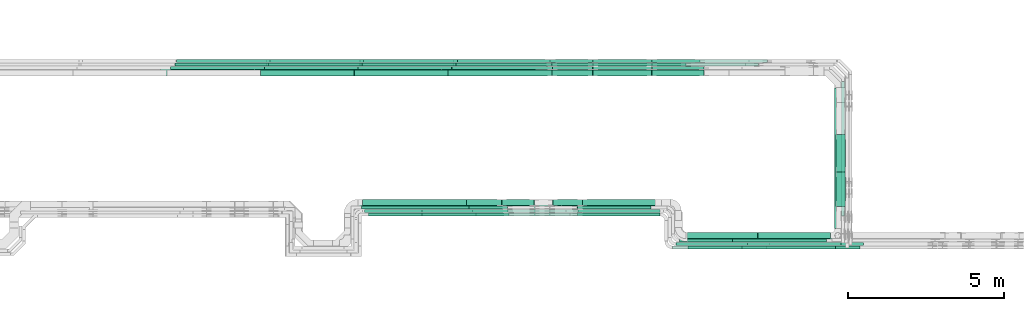
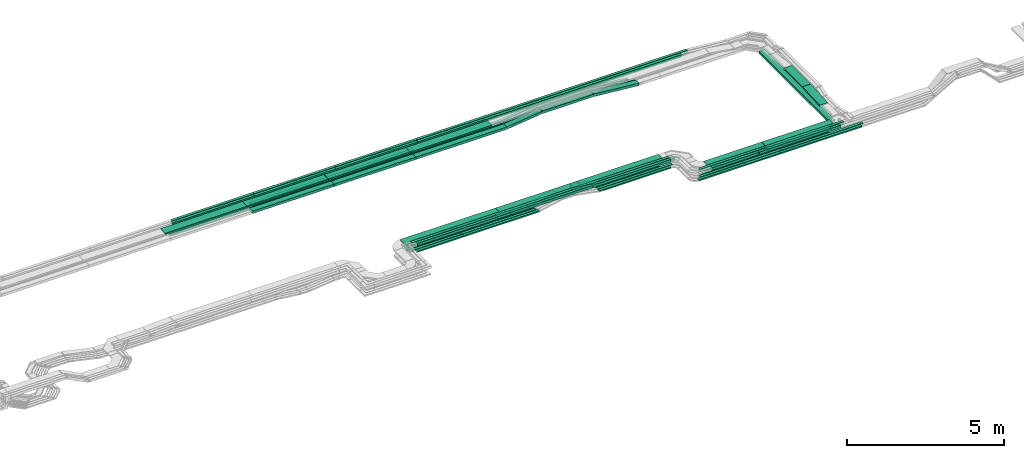
# One storey, part 3 of 32: 78 flow segments.
"""IFC2X3 building model written with IfcOpenShell, lengths in millimetres."""

from ifc_helpers import new_model, entity, si_unit, converted_unit, derived_unit, direction, frame, frame_2d, origin, origin_2d_with_axis, place, context, subcontext, project, spatial, rectangle, extrude, type_object, element, save


model = new_model("IFC2X3")

# Units and contexts
model_context = context("Model", 3, precision=0.01, world=origin(), true_north=direction((6.12303176911189e-17, 1.0)))
body_context = subcontext(model_context, "Body", "Model", "MODEL_VIEW")
ifc_project = project(units=[si_unit("LENGTHUNIT", "METRE", prefix="MILLI"), si_unit("AREAUNIT", "SQUARE_METRE"), si_unit("VOLUMEUNIT", "CUBIC_METRE"), converted_unit("PLANEANGLEUNIT", "DEGREE", entity("IfcRatioMeasure", 0.0174532925199433), si_unit("PLANEANGLEUNIT", "RADIAN"), dimensions=[0, 0, 0, 0, 0, 0, 0]), si_unit("MASSUNIT", "GRAM", prefix="KILO"), derived_unit("MASSDENSITYUNIT", [(si_unit("MASSUNIT", "GRAM", prefix="KILO"), 1), (si_unit("LENGTHUNIT", "METRE"), -3)]), derived_unit("MOMENTOFINERTIAUNIT", [(si_unit("LENGTHUNIT", "METRE"), 4)]), si_unit("TIMEUNIT", "SECOND"), si_unit("FREQUENCYUNIT", "HERTZ"), si_unit("THERMODYNAMICTEMPERATUREUNIT", "DEGREE_CELSIUS"), derived_unit("THERMALTRANSMITTANCEUNIT", [(si_unit("MASSUNIT", "GRAM", prefix="KILO"), 1), (si_unit("THERMODYNAMICTEMPERATUREUNIT", "KELVIN"), -1), (si_unit("TIMEUNIT", "SECOND"), -3)]), derived_unit("VOLUMETRICFLOWRATEUNIT", [(si_unit("LENGTHUNIT", "METRE"), 3), (si_unit("TIMEUNIT", "SECOND"), -1)]), derived_unit("MASSFLOWRATEUNIT", [(si_unit("MASSUNIT", "GRAM", prefix="KILO"), 1), (si_unit("TIMEUNIT", "SECOND"), -1)]), derived_unit("ROTATIONALFREQUENCYUNIT", [(si_unit("TIMEUNIT", "SECOND"), -1)]), si_unit("ELECTRICCURRENTUNIT", "AMPERE"), si_unit("ELECTRICVOLTAGEUNIT", "VOLT"), si_unit("POWERUNIT", "WATT"), si_unit("FORCEUNIT", "NEWTON", prefix="KILO"), si_unit("ILLUMINANCEUNIT", "LUX"), si_unit("LUMINOUSFLUXUNIT", "LUMEN"), si_unit("LUMINOUSINTENSITYUNIT", "CANDELA"), derived_unit("USERDEFINED", [(si_unit("MASSUNIT", "GRAM", prefix="KILO"), -1), (si_unit("LENGTHUNIT", "METRE"), -2), (si_unit("TIMEUNIT", "SECOND"), 3), (si_unit("LUMINOUSFLUXUNIT", "LUMEN"), 1)]), derived_unit("LINEARVELOCITYUNIT", [(si_unit("LENGTHUNIT", "METRE"), 1), (si_unit("TIMEUNIT", "SECOND"), -1)]), si_unit("PRESSUREUNIT", "PASCAL"), derived_unit("USERDEFINED", [(si_unit("LENGTHUNIT", "METRE"), -2), (si_unit("MASSUNIT", "GRAM", prefix="KILO"), 1), (si_unit("TIMEUNIT", "SECOND"), -2)]), derived_unit("LINEARFORCEUNIT", [(si_unit("MASSUNIT", "GRAM", prefix="KILO"), 1), (si_unit("LENGTHUNIT", "METRE"), 1), (si_unit("TIMEUNIT", "SECOND"), -2), (si_unit("LENGTHUNIT", "METRE"), -1)]), derived_unit("PLANARFORCEUNIT", [(si_unit("MASSUNIT", "GRAM", prefix="KILO"), 1), (si_unit("LENGTHUNIT", "METRE"), 1), (si_unit("TIMEUNIT", "SECOND"), -2), (si_unit("LENGTHUNIT", "METRE"), -2)])], contexts=[model_context])

# Site, building, storey
site_placement = place(None, origin())
site = spatial("IfcSite", under=ifc_project, at=site_placement, CompositionType="ELEMENT")
building_placement = place(site_placement, origin())
building = spatial("IfcBuilding", under=site, at=building_placement, CompositionType="ELEMENT")
storey_placement = place(building_placement, frame((0.0, 0.0, 8100.0)))
storey = spatial("IfcBuildingStorey", under=building, at=storey_placement, CompositionType="ELEMENT", Elevation=8100.0)

# Flow segments
cable_carrier_segment_type = type_object("IfcCableCarrierSegmentType", PredefinedType="CABLETRAYSEGMENT")
flow_segment_1_placement = place(storey_placement, frame((45344.9, 9694.99, 2799.27)))
element("IfcFlowSegment", 1, at=flow_segment_1_placement, inside=storey, type_object=cable_carrier_segment_type, context=body_context, shape_type="SweptSolid", body=[
    extrude(rectangle(XDim=99.9999999999999, YDim=3442.93310217287, at=frame_2d((0.0, 0.0), x_axis=(0.0, 1.0))), frame((1721.47, 50.0, 0.01), z_axis=(4.01733183785302e-07, 0.000204778842241825, 0.999999979032732), x_axis=(1.0, 0.0, -4.01733192208904e-07)), (0.0, 0.0, 1.0), 100.0),
])
flow_segment_2_placement = place(storey_placement, frame((60470.11, 9693.6, 2550.0)))
element("IfcFlowSegment", 2, at=flow_segment_2_placement, inside=storey, type_object=cable_carrier_segment_type, context=body_context, shape_type="SweptSolid", body=[
    extrude(rectangle(XDim=4312.67919252471, YDim=99.9999999999946, at=origin_2d_with_axis()), frame((50.0, 2156.34, 0.0), z_axis=(0.0, 0.0, 1.0), x_axis=(0.0, -1.0, 0.0)), (0.0, 0.0, 1.0), 50.0000000000038),
])
flow_segment_3_placement = place(storey_placement, frame((55181.11, 8749.98, 2549.87)))
element("IfcFlowSegment", 3, at=flow_segment_3_placement, inside=storey, type_object=cable_carrier_segment_type, context=body_context, shape_type="SweptSolid", body=[
    extrude(rectangle(XDim=2998.73000000509, YDim=99.9999999999989, at=origin_2d_with_axis()), frame((1499.37, 50.0, 0.0)), (0.0, 0.0, 1.0), 49.9999999999995),
])
flow_segment_4_placement = place(storey_placement, frame((55071.11, 8639.98, 2548.16)))
element("IfcFlowSegment", 4, at=flow_segment_4_placement, inside=storey, type_object=cable_carrier_segment_type, context=body_context, shape_type="SweptSolid", body=[
    extrude(rectangle(XDim=2998.73000000509, YDim=100.000000000001, at=origin_2d_with_axis()), frame((1499.37, 50.0, 0.0)), (0.0, 0.0, 1.0), 49.9999999999995),
])
flow_segment_5_placement = place(storey_placement, frame((47050.03, 9805.0, 2546.32)))
element("IfcFlowSegment", 5, at=flow_segment_5_placement, inside=storey, type_object=cable_carrier_segment_type, context=body_context, shape_type="SweptSolid", body=[
    extrude(rectangle(XDim=2747.08735792927, YDim=99.9999999999989, at=origin_2d_with_axis()), frame((1373.54, 50.0, 0.0)), (0.0, 0.0, 1.0), 50.0000000000016),
])
flow_segment_6_placement = place(storey_placement, frame((45109.39, 9915.0, 2544.93)))
element("IfcFlowSegment", 6, at=flow_segment_6_placement, inside=storey, type_object=cable_carrier_segment_type, context=body_context, shape_type="SweptSolid", body=[
    extrude(rectangle(XDim=3442.93310217291, YDim=99.9999999999989, at=origin_2d_with_axis()), frame((1721.47, 50.0, 0.0)), (0.0, 0.0, 1.0), 50.0000000000016),
])
flow_segment_7_placement = place(storey_placement, frame((45145.39, 10025.0, 2547.39)))
element("IfcFlowSegment", 7, at=flow_segment_7_placement, inside=storey, type_object=cable_carrier_segment_type, context=body_context, shape_type="SweptSolid", body=[
    extrude(rectangle(XDim=3327.94024484785, YDim=200.000000000002, at=origin_2d_with_axis()), frame((1663.97, 100.0, 0.0)), (0.0, 0.0, 1.0), 99.9999999999989),
])
flow_segment_8_placement = place(storey_placement, frame((47050.03, 9695.0, 2546.67)))
element("IfcFlowSegment", 8, at=flow_segment_8_placement, inside=storey, type_object=cable_carrier_segment_type, context=body_context, shape_type="SweptSolid", body=[
    extrude(rectangle(XDim=2786.58976200292, YDim=99.9999999999989, at=origin_2d_with_axis()), frame((1393.29, 50.0, 0.0)), (0.0, 0.0, 1.0), 50.0000000000016),
])
flow_segment_9_placement = place(storey_placement, frame((52023.2, 9915.0, 2549.87)))
element("IfcFlowSegment", 9, at=flow_segment_9_placement, inside=storey, type_object=cable_carrier_segment_type, context=body_context, shape_type="SweptSolid", body=[
    extrude(rectangle(XDim=2356.3241779721, YDim=99.9999999999989, at=origin_2d_with_axis()), frame((1178.16, 50.0, 0.0), z_axis=(0.0, 0.0, 1.0), x_axis=(-1.0, 0.0, 0.0)), (0.0, 0.0, 1.0), 50.0000000000016),
])
flow_segment_10_placement = place(storey_placement, frame((52525.14, 14174.5, 2704.58)))
element("IfcFlowSegment", 10, at=flow_segment_10_placement, inside=storey, type_object=cable_carrier_segment_type, context=body_context, shape_type="SweptSolid", body=[
    extrude(rectangle(XDim=1876.86289906557, YDim=200.000000000002, at=origin_2d_with_axis()), frame((938.43, 100.0, 0.0)), (0.0, 0.0, 1.0), 99.9999999999989),
])
flow_segment_11_placement = place(storey_placement, frame((52523.64, 14382.28, 2704.03)))
element("IfcFlowSegment", 11, at=flow_segment_11_placement, inside=storey, type_object=cable_carrier_segment_type, context=body_context, shape_type="SweptSolid", body=[
    extrude(rectangle(XDim=1879.49381672388, YDim=99.9999999999989, at=origin_2d_with_axis()), frame((939.75, 50.0, 0.0), z_axis=(0.0, 0.0, 1.0), x_axis=(-1.0, 0.0, 0.0)), (0.0, 0.0, 1.0), 50.0000000000016),
])
flow_segment_12_placement = place(storey_placement, frame((52525.62, 14492.28, 2704.02)))
element("IfcFlowSegment", 12, at=flow_segment_12_placement, inside=storey, type_object=cable_carrier_segment_type, context=body_context, shape_type="SweptSolid", body=[
    extrude(rectangle(XDim=1881.17742834909, YDim=99.9999999999989, at=origin_2d_with_axis()), frame((940.59, 50.0, 0.0), z_axis=(0.0, 0.0, 1.0), x_axis=(-1.0, 0.0, 0.0)), (0.0, 0.0, 1.0), 50.0000000000016),
])
flow_segment_13_placement = place(storey_placement, frame((52523.56, 14602.28, 2704.5)))
element("IfcFlowSegment", 13, at=flow_segment_13_placement, inside=storey, type_object=cable_carrier_segment_type, context=body_context, shape_type="SweptSolid", body=[
    extrude(rectangle(XDim=1879.86643624629, YDim=99.9999999999989, at=origin_2d_with_axis()), frame((939.93, 50.0, 0.0), z_axis=(0.0, 0.0, 1.0), x_axis=(-1.0, 0.0, 0.0)), (0.0, 0.0, 1.0), 50.0000000000016),
])
flow_segment_14_placement = place(storey_placement, frame((48186.7, 14602.28, 2855.0)))
element("IfcFlowSegment", 14, at=flow_segment_14_placement, inside=storey, type_object=cable_carrier_segment_type, context=body_context, shape_type="SweptSolid", body=[
    extrude(rectangle(XDim=9916.000468824, YDim=99.9999999999989, at=origin_2d_with_axis()), frame((4958.0, 50.0, 0.0), z_axis=(0.0, 0.0, 1.0), x_axis=(-1.0, 0.0, 0.0)), (0.0, 0.0, 1.0), 99.9999999999989),
])
flow_segment_15_placement = place(storey_placement, frame((48139.57, 14492.28, 2855.0)))
element("IfcFlowSegment", 15, at=flow_segment_15_placement, inside=storey, type_object=cable_carrier_segment_type, context=body_context, shape_type="SweptSolid", body=[
    extrude(rectangle(XDim=9680.19408379606, YDim=99.9999999999989, at=origin_2d_with_axis()), frame((4840.1, 50.0, 0.0), z_axis=(0.0, 0.0, 1.0), x_axis=(-1.0, 0.0, 0.0)), (0.0, 0.0, 1.0), 100.000000000001),
])
flow_segment_16_placement = place(storey_placement, frame((54405.82, 14602.28, 2550.37)))
element("IfcFlowSegment", 16, at=flow_segment_16_placement, inside=storey, type_object=cable_carrier_segment_type, context=body_context, shape_type="SweptSolid", body=[
    extrude(rectangle(XDim=50.0000000000019, YDim=99.9999999999989, at=frame_2d((0.0, 0.0), x_axis=(0.0, 1.0))), frame((2.49, 50.0, 178.89), z_axis=(0.995008976454959, 0.0, -0.0997854537197453), x_axis=(0.0, 1.0, 0.0)), (0.0, 0.0, 1.0), 1543.44232698593),
])
flow_segment_17_placement = place(storey_placement, frame((51155.3, 14602.28, 2549.33)))
element("IfcFlowSegment", 17, at=flow_segment_17_placement, inside=storey, type_object=cable_carrier_segment_type, context=body_context, shape_type="SweptSolid", body=[
    extrude(rectangle(XDim=49.9999999999997, YDim=99.9999999999989, at=frame_2d((0.0, 0.0), x_axis=(0.0, 1.0))), frame((2.83, 50.0, 24.84), z_axis=(0.993566510793554, 0.0, 0.113250115362077), x_axis=(0.0, 1.0, 0.0)), (0.0, 0.0, 1.0), 1368.9632988374),
])
flow_segment_18_placement = place(storey_placement, frame((51204.64, 14492.28, 2548.84)))
element("IfcFlowSegment", 18, at=flow_segment_18_placement, inside=storey, type_object=cable_carrier_segment_type, context=body_context, shape_type="SweptSolid", body=[
    extrude(rectangle(XDim=50.0000000000001, YDim=99.9999999999989, at=origin_2d_with_axis()), frame((2.93, 50.0, 24.83), z_axis=(0.993097003616306, 0.0, 0.117295956487492), x_axis=(-0.117295956487492, 0.0, 0.993097003616306)), (0.0, 0.0, 1.0), 1321.78049567335),
])
flow_segment_19_placement = place(storey_placement, frame((54409.35, 14492.28, 2550.67)))
element("IfcFlowSegment", 19, at=flow_segment_19_placement, inside=storey, type_object=cable_carrier_segment_type, context=body_context, shape_type="SweptSolid", body=[
    extrude(rectangle(XDim=50.0000000000019, YDim=99.9999999999989, at=frame_2d((0.0, 0.0), x_axis=(0.0, 1.0))), frame((3.49, 50.0, 177.93), z_axis=(0.990180361963206, 0.0, -0.139795746653517), x_axis=(0.0, 1.0, 0.0)), (0.0, 0.0, 1.0), 1095.69661901961),
])
flow_segment_20_placement = place(storey_placement, frame((54405.5, 14382.28, 2550.32)))
element("IfcFlowSegment", 20, at=flow_segment_20_placement, inside=storey, type_object=cable_carrier_segment_type, context=body_context, shape_type="SweptSolid", body=[
    extrude(rectangle(XDim=49.9999999999988, YDim=99.9999999999989, at=origin_2d_with_axis()), frame((2.29, 50.0, 178.5), z_axis=(0.995808315172805, 0.0, -0.0914647442061654), x_axis=(0.0914647442061654, 0.0, 0.995808315172805)), (0.0, 0.0, 1.0), 1679.34670108359),
])
flow_segment_21_placement = place(storey_placement, frame((51225.84, 14382.28, 2549.38)))
element("IfcFlowSegment", 21, at=flow_segment_21_placement, inside=storey, type_object=cable_carrier_segment_type, context=body_context, shape_type="SweptSolid", body=[
    extrude(rectangle(XDim=50.0000000000011, YDim=99.9999999999989, at=frame_2d((0.0, 0.0), x_axis=(0.0, 1.0))), frame((2.97, 50.0, 24.82), z_axis=(0.992897734535622, 0.0, 0.118970957607431), x_axis=(0.0, 1.0, 0.0)), (0.0, 0.0, 1.0), 1298.61326955361),
])
flow_segment_22_placement = place(storey_placement, frame((54404.36, 14174.5, 2550.53)))
element("IfcFlowSegment", 22, at=flow_segment_22_placement, inside=storey, type_object=cable_carrier_segment_type, context=body_context, shape_type="SweptSolid", body=[
    extrude(rectangle(XDim=99.999999999999, YDim=200.000000000002, at=origin_2d_with_axis()), frame((4.59, 100.0, 203.73), z_axis=(0.995778345359133, 0.0, -0.0917904511037341), x_axis=(0.0917904511037341, 0.0, 0.995778345359133)), (0.0, 0.0, 1.0), 1677.07211589127),
])
flow_segment_23_placement = place(storey_placement, frame((51219.72, 14174.5, 2549.73)))
element("IfcFlowSegment", 23, at=flow_segment_23_placement, inside=storey, type_object=cable_carrier_segment_type, context=body_context, shape_type="SweptSolid", body=[
    extrude(rectangle(XDim=100.0, YDim=200.000000000002, at=frame_2d((0.0, 0.0), x_axis=(0.0, 1.0))), frame((5.95, 100.0, 49.64), z_axis=(0.992897734535643, 0.0, 0.11897095760726), x_axis=(0.0, 1.0, 0.0)), (0.0, 0.0, 1.0), 1300.29007254466),
])
flow_segment_24_placement = place(storey_placement, frame((45008.7, 9925.0, 2796.03)))
element("IfcFlowSegment", 24, at=flow_segment_24_placement, inside=storey, type_object=cable_carrier_segment_type, context=body_context, shape_type="SweptSolid", body=[
    extrude(rectangle(XDim=3498.71922401121, YDim=299.999999995752, at=origin_2d_with_axis()), frame((1749.36, 150.0, 1.84), z_axis=(0.00105003504091696, 0.0, 0.999999448713054), x_axis=(0.999999448713054, 0.0, -0.00105003504091696)), (0.0, 0.0, 1.0), 49.9999999992948),
])
flow_segment_25_placement = place(storey_placement, frame((45219.39, 9805.0, 2799.94)))
element("IfcFlowSegment", 25, at=flow_segment_25_placement, inside=storey, type_object=cable_carrier_segment_type, context=body_context, shape_type="SweptSolid", body=[
    extrude(rectangle(XDim=3442.93310207175, YDim=99.9999999827077, at=origin_2d_with_axis()), frame((1721.47, 50.0, 0.03)), (0.0, 0.0, 1.0), 99.9999999827065),
])
for number, where in (
    (26, (42074.45, 14602.28, 2548.87)),
    (27, (45074.45, 14602.28, 2548.87)),
):
    element("IfcFlowSegment", number, at=place(storey_placement, frame(where)), inside=storey, type_object=cable_carrier_segment_type, context=body_context, shape_type="SweptSolid", body=[
        extrude(rectangle(XDim=2997.46000001017, YDim=99.9999999999989, at=origin_2d_with_axis()), frame((1498.73, 50.0, 0.0)), (0.0, 0.0, 1.0), 50.0000000000016),
    ])
flow_segment_26_placement = place(storey_placement, frame((48074.45, 14602.28, 2548.87)))
element("IfcFlowSegment", 28, at=flow_segment_26_placement, inside=storey, type_object=cable_carrier_segment_type, context=body_context, shape_type="SweptSolid", body=[
    extrude(rectangle(XDim=3078.40248337126, YDim=99.9999999999989, at=origin_2d_with_axis()), frame((1539.2, 50.0, 0.0)), (0.0, 0.0, 1.0), 50.0000000000016),
])
flow_segment_27_placement = place(storey_placement, frame((42068.97, 14492.28, 2548.35)))
element("IfcFlowSegment", 29, at=flow_segment_27_placement, inside=storey, type_object=cable_carrier_segment_type, context=body_context, shape_type="SweptSolid", body=[
    extrude(rectangle(XDim=2997.46000001017, YDim=99.9999999999989, at=origin_2d_with_axis()), frame((1498.73, 50.0, 0.0)), (0.0, 0.0, 1.0), 50.0000000000016),
])
flow_segment_28_placement = place(storey_placement, frame((45068.97, 14492.28, 2548.35)))
element("IfcFlowSegment", 30, at=flow_segment_28_placement, inside=storey, type_object=cable_carrier_segment_type, context=body_context, shape_type="SweptSolid", body=[
    extrude(rectangle(XDim=2997.46000001016, YDim=99.9999999999989, at=origin_2d_with_axis()), frame((1498.73, 50.0, 0.0)), (0.0, 0.0, 1.0), 50.0000000000016),
])
flow_segment_29_placement = place(storey_placement, frame((48068.97, 14492.28, 2548.35)))
element("IfcFlowSegment", 31, at=flow_segment_29_placement, inside=storey, type_object=cable_carrier_segment_type, context=body_context, shape_type="SweptSolid", body=[
    extrude(rectangle(XDim=3133.20469466123, YDim=99.9999999999989, at=origin_2d_with_axis()), frame((1566.6, 50.0, 0.0)), (0.0, 0.0, 1.0), 50.0000000000016),
])
flow_segment_30_placement = place(storey_placement, frame((58182.38, 8749.98, 2549.87)))
element("IfcFlowSegment", 32, at=flow_segment_30_placement, inside=storey, type_object=cable_carrier_segment_type, context=body_context, shape_type="SweptSolid", body=[
    extrude(rectangle(XDim=2997.46000001017, YDim=99.9999999999989, at=origin_2d_with_axis()), frame((1498.73, 50.0, 0.0)), (0.0, 0.0, 1.0), 50.0000000000016),
])
flow_segment_31_placement = place(storey_placement, frame((45140.39, 9805.0, 2546.32)))
element("IfcFlowSegment", 33, at=flow_segment_31_placement, inside=storey, type_object=cable_carrier_segment_type, context=body_context, shape_type="SweptSolid", body=[
    extrude(rectangle(XDim=1907.10199601725, YDim=99.9999999999989, at=origin_2d_with_axis()), frame((953.55, 50.0, 0.0), z_axis=(0.0, 0.0, 1.0), x_axis=(-1.0, 0.0, 0.0)), (0.0, 0.0, 1.0), 50.0000000000016),
])
for number, where in (
    (34, (39139.57, 14492.28, 2855.0)),
    (35, (42139.57, 14492.28, 2855.0)),
    (36, (45139.57, 14492.28, 2855.0)),
):
    element("IfcFlowSegment", number, at=place(storey_placement, frame(where)), inside=storey, type_object=cable_carrier_segment_type, context=body_context, shape_type="SweptSolid", body=[
        extrude(rectangle(XDim=2997.46000001017, YDim=99.9999999999989, at=origin_2d_with_axis()), frame((1498.73, 50.0, 0.0)), (0.0, 0.0, 1.0), 99.9999999999989),
    ])
flow_segment_32_placement = place(storey_placement, frame((41884.54, 14174.5, 2548.88)))
element("IfcFlowSegment", 37, at=flow_segment_32_placement, inside=storey, type_object=cable_carrier_segment_type, context=body_context, shape_type="SweptSolid", body=[
    extrude(rectangle(XDim=2997.46000001017, YDim=199.999999999998, at=origin_2d_with_axis()), frame((1498.73, 100.0, 0.0)), (0.0, 0.0, 1.0), 99.9999999999989),
])
flow_segment_33_placement = place(storey_placement, frame((44884.54, 14174.5, 2548.88)))
element("IfcFlowSegment", 38, at=flow_segment_33_placement, inside=storey, type_object=cable_carrier_segment_type, context=body_context, shape_type="SweptSolid", body=[
    extrude(rectangle(XDim=2997.46000001016, YDim=199.999999999998, at=origin_2d_with_axis()), frame((1498.73, 100.0, 0.0)), (0.0, 0.0, 1.0), 99.9999999999989),
])
flow_segment_34_placement = place(storey_placement, frame((47884.54, 14174.5, 2548.88)))
element("IfcFlowSegment", 39, at=flow_segment_34_placement, inside=storey, type_object=cable_carrier_segment_type, context=body_context, shape_type="SweptSolid", body=[
    extrude(rectangle(XDim=3332.70440700738, YDim=199.999999999998, at=origin_2d_with_axis()), frame((1666.35, 100.0, 0.0)), (0.0, 0.0, 1.0), 99.9999999999989),
])
flow_segment_35_placement = place(storey_placement, frame((38684.77, 14182.28, 2854.5)))
element("IfcFlowSegment", 40, at=flow_segment_35_placement, inside=storey, type_object=cable_carrier_segment_type, context=body_context, shape_type="SweptSolid", body=[
    extrude(rectangle(XDim=2997.46000001016, YDim=300.000000000001, at=origin_2d_with_axis()), frame((1498.73, 150.0, 0.0)), (0.0, 0.0, 1.0), 50.0000000000016),
])
flow_segment_36_placement = place(storey_placement, frame((41684.77, 14182.28, 2854.5)))
element("IfcFlowSegment", 41, at=flow_segment_36_placement, inside=storey, type_object=cable_carrier_segment_type, context=body_context, shape_type="SweptSolid", body=[
    extrude(rectangle(XDim=2997.46000001017, YDim=300.000000000001, at=origin_2d_with_axis()), frame((1498.73, 150.0, 0.0)), (0.0, 0.0, 1.0), 50.0000000000038),
])
flow_segment_37_placement = place(storey_placement, frame((44684.77, 14182.28, 2854.5)))
element("IfcFlowSegment", 42, at=flow_segment_37_placement, inside=storey, type_object=cable_carrier_segment_type, context=body_context, shape_type="SweptSolid", body=[
    extrude(rectangle(XDim=2997.46000001017, YDim=300.000000000001, at=origin_2d_with_axis()), frame((1498.73, 150.0, 0.0)), (0.0, 0.0, 1.0), 50.0000000000016),
])
flow_segment_38_placement = place(storey_placement, frame((47684.77, 14182.28, 2854.5)))
element("IfcFlowSegment", 43, at=flow_segment_38_placement, inside=storey, type_object=cable_carrier_segment_type, context=body_context, shape_type="SweptSolid", body=[
    extrude(rectangle(XDim=2997.46000001016, YDim=300.000000000001, at=origin_2d_with_axis()), frame((1498.73, 150.0, 0.0)), (0.0, 0.0, 1.0), 50.0000000000038),
])
flow_segment_39_placement = place(storey_placement, frame((55501.11, 8969.98, 2549.84)))
element("IfcFlowSegment", 44, at=flow_segment_39_placement, inside=storey, type_object=cable_carrier_segment_type, context=body_context, shape_type="SweptSolid", body=[
    extrude(rectangle(XDim=2294.80992749182, YDim=200.0, at=origin_2d_with_axis()), frame((1147.4, 100.0, 0.0), z_axis=(0.0, 0.0, 1.0), x_axis=(-1.0, 0.0, 0.0)), (0.0, 0.0, 1.0), 99.9999999999989),
])
flow_segment_40_placement = place(storey_placement, frame((48475.87, 10025.0, 2547.39)))
element("IfcFlowSegment", 45, at=flow_segment_40_placement, inside=storey, type_object=cable_carrier_segment_type, context=body_context, shape_type="SweptSolid", body=[
    extrude(rectangle(XDim=1127.1073315062, YDim=199.999999999998, at=origin_2d_with_axis()), frame((563.55, 100.0, 0.0)), (0.0, 0.0, 1.0), 99.9999999999989),
])
flow_segment_41_placement = place(storey_placement, frame((55543.56, 8869.98, 2788.92)))
element("IfcFlowSegment", 46, at=flow_segment_41_placement, inside=storey, type_object=cable_carrier_segment_type, context=body_context, shape_type="SweptSolid", body=[
    extrude(rectangle(XDim=2134.15215708081, YDim=300.000000000001, at=origin_2d_with_axis()), frame((1067.08, 150.0, 0.0), z_axis=(0.0, 0.0, 1.0), x_axis=(-1.0, 0.0, 0.0)), (0.0, 0.0, 1.0), 50.0000000000016),
])
flow_segment_42_placement = place(storey_placement, frame((48509.95, 9925.0, 2792.88)))
element("IfcFlowSegment", 47, at=flow_segment_42_placement, inside=storey, type_object=cable_carrier_segment_type, context=body_context, shape_type="SweptSolid", body=[
    extrude(rectangle(XDim=2997.46000001016, YDim=300.000000000001, at=origin_2d_with_axis()), frame((1498.73, 150.0, 1.57), z_axis=(0.0010500350409279, 0.0, 0.999999448713054), x_axis=(0.999999448713054, 0.0, -0.0010500350409279)), (0.0, 0.0, 1.0), 50.0000000000008),
])
flow_segment_43_placement = place(storey_placement, frame((51509.95, 9925.0, 2789.73)))
element("IfcFlowSegment", 48, at=flow_segment_43_placement, inside=storey, type_object=cable_carrier_segment_type, context=body_context, shape_type="SweptSolid", body=[
    extrude(rectangle(XDim=2997.46000001017, YDim=300.000000000001, at=origin_2d_with_axis()), frame((1498.73, 150.0, 1.57), z_axis=(0.0010500350409279, 0.0, 0.999999448713054), x_axis=(0.999999448713054, 0.0, -0.0010500350409279)), (0.0, 0.0, 1.0), 50.0000000000008),
])
flow_segment_44_placement = place(storey_placement, frame((48790.37, 9695.0, 2799.28)))
element("IfcFlowSegment", 49, at=flow_segment_44_placement, inside=storey, type_object=cable_carrier_segment_type, context=body_context, shape_type="SweptSolid", body=[
    extrude(rectangle(XDim=2997.46000001017, YDim=99.9999999999989, at=origin_2d_with_axis()), frame((1498.73, 50.0, 0.0)), (0.0, 0.0, 1.0), 100.000000000001),
])
flow_segment_45_placement = place(storey_placement, frame((51790.37, 9695.0, 2799.28)))
element("IfcFlowSegment", 50, at=flow_segment_45_placement, inside=storey, type_object=cable_carrier_segment_type, context=body_context, shape_type="SweptSolid", body=[
    extrude(rectangle(XDim=2878.73960950955, YDim=99.9999999999989, at=origin_2d_with_axis()), frame((1439.37, 50.0, 0.0)), (0.0, 0.0, 1.0), 100.000000000001),
])
flow_segment_46_placement = place(storey_placement, frame((39186.7, 14602.28, 2855.0)))
element("IfcFlowSegment", 51, at=flow_segment_46_placement, inside=storey, type_object=cable_carrier_segment_type, context=body_context, shape_type="SweptSolid", body=[
    extrude(rectangle(XDim=2997.46000001017, YDim=99.9999999999989, at=origin_2d_with_axis()), frame((1498.73, 50.0, 0.0)), (0.0, 0.0, 1.0), 99.9999999999989),
])
flow_segment_47_placement = place(storey_placement, frame((42186.7, 14602.28, 2855.0)))
element("IfcFlowSegment", 52, at=flow_segment_47_placement, inside=storey, type_object=cable_carrier_segment_type, context=body_context, shape_type="SweptSolid", body=[
    extrude(rectangle(XDim=2997.46000001016, YDim=99.9999999999989, at=origin_2d_with_axis()), frame((1498.73, 50.0, 0.0)), (0.0, 0.0, 1.0), 99.9999999999989),
])
flow_segment_48_placement = place(storey_placement, frame((45186.7, 14602.28, 2855.0)))
element("IfcFlowSegment", 53, at=flow_segment_48_placement, inside=storey, type_object=cable_carrier_segment_type, context=body_context, shape_type="SweptSolid", body=[
    extrude(rectangle(XDim=2997.46000001017, YDim=99.9999999999989, at=origin_2d_with_axis()), frame((1498.73, 50.0, 0.0)), (0.0, 0.0, 1.0), 99.9999999999989),
])
flow_segment_49_placement = place(storey_placement, frame((39006.52, 14382.28, 2548.88)))
element("IfcFlowSegment", 54, at=flow_segment_49_placement, inside=storey, type_object=cable_carrier_segment_type, context=body_context, shape_type="SweptSolid", body=[
    extrude(rectangle(XDim=2997.46000001016, YDim=99.9999999999989, at=origin_2d_with_axis()), frame((1498.73, 50.0, 0.0)), (0.0, 0.0, 1.0), 50.0000000000038),
])
for number, where in (
    (55, (42006.52, 14382.28, 2548.88)),
    (56, (45006.52, 14382.28, 2548.88)),
):
    element("IfcFlowSegment", number, at=place(storey_placement, frame(where)), inside=storey, type_object=cable_carrier_segment_type, context=body_context, shape_type="SweptSolid", body=[
        extrude(rectangle(XDim=2997.46000001017, YDim=99.9999999999989, at=origin_2d_with_axis()), frame((1498.73, 50.0, 0.0)), (0.0, 0.0, 1.0), 50.0000000000016),
    ])
flow_segment_50_placement = place(storey_placement, frame((48006.52, 14382.28, 2548.88)))
element("IfcFlowSegment", 57, at=flow_segment_50_placement, inside=storey, type_object=cable_carrier_segment_type, context=body_context, shape_type="SweptSolid", body=[
    extrude(rectangle(XDim=3216.84887679289, YDim=99.9999999999989, at=origin_2d_with_axis()), frame((1608.42, 50.0, 0.0)), (0.0, 0.0, 1.0), 50.0000000000016),
])
flow_segment_51_placement = place(storey_placement, frame((56995.4, 8859.98, 2549.87)))
element("IfcFlowSegment", 58, at=flow_segment_51_placement, inside=storey, type_object=cable_carrier_segment_type, context=body_context, shape_type="SweptSolid", body=[
    extrude(rectangle(XDim=2997.46000001017, YDim=100.000000000001, at=origin_2d_with_axis()), frame((1498.73, 50.0, 0.0), z_axis=(0.0, 0.0, 1.0), x_axis=(-1.0, 0.0, 0.0)), (0.0, 0.0, 1.0), 50.0000000000016),
])
flow_segment_52_placement = place(storey_placement, frame((55291.11, 8859.98, 2549.87)))
element("IfcFlowSegment", 59, at=flow_segment_52_placement, inside=storey, type_object=cable_carrier_segment_type, context=body_context, shape_type="SweptSolid", body=[
    extrude(rectangle(XDim=1701.75556828602, YDim=100.000000000001, at=origin_2d_with_axis()), frame((850.88, 50.0, 0.0), z_axis=(0.0, 0.0, 1.0), x_axis=(-1.0, 0.0, 0.0)), (0.0, 0.0, 1.0), 50.0000000000016),
])
flow_segment_53_placement = place(storey_placement, frame((58072.38, 8639.98, 2548.16)))
element("IfcFlowSegment", 60, at=flow_segment_53_placement, inside=storey, type_object=cable_carrier_segment_type, context=body_context, shape_type="SweptSolid", body=[
    extrude(rectangle(XDim=2997.46000001016, YDim=100.000000000001, at=origin_2d_with_axis()), frame((1498.73, 50.0, 0.0)), (0.0, 0.0, 1.0), 50.0000000000016),
])
flow_segment_54_placement = place(storey_placement, frame((48554.86, 9915.0, 2544.93)))
element("IfcFlowSegment", 61, at=flow_segment_54_placement, inside=storey, type_object=cable_carrier_segment_type, context=body_context, shape_type="SweptSolid", body=[
    extrude(rectangle(XDim=1227.26174799622, YDim=99.9999999999989, at=origin_2d_with_axis()), frame((613.63, 50.0, 0.0)), (0.0, 0.0, 1.0), 50.0000000000016),
])
flow_segment_55_placement = place(storey_placement, frame((45329.9, 9695.0, 2546.67)))
element("IfcFlowSegment", 62, at=flow_segment_55_placement, inside=storey, type_object=cable_carrier_segment_type, context=body_context, shape_type="SweptSolid", body=[
    extrude(rectangle(XDim=1717.59567755898, YDim=99.9999999999989, at=origin_2d_with_axis()), frame((858.8, 50.0, 0.0), z_axis=(0.0, 0.0, 1.0), x_axis=(-1.0, 0.0, 0.0)), (0.0, 0.0, 1.0), 50.0000000000016),
])
flow_segment_56_placement = place(storey_placement, frame((57465.04, 8749.98, 2800.01)))
element("IfcFlowSegment", 63, at=flow_segment_56_placement, inside=storey, type_object=cable_carrier_segment_type, context=body_context, shape_type="SweptSolid", body=[
    extrude(rectangle(XDim=2997.46000001017, YDim=100.000000000001, at=origin_2d_with_axis()), frame((1498.73, 50.0, 0.0), z_axis=(8.83740173844426e-07, 0.0, 1.0), x_axis=(-1.0, 0.0, 8.83740173844426e-07)), (0.0, 0.0, 1.0), 99.999999999999),
])
flow_segment_57_placement = place(storey_placement, frame((55181.33, 8749.98, 2800.02)))
element("IfcFlowSegment", 64, at=flow_segment_57_placement, inside=storey, type_object=cable_carrier_segment_type, context=body_context, shape_type="SweptSolid", body=[
    extrude(rectangle(XDim=2281.16223717898, YDim=99.9999999999989, at=origin_2d_with_axis()), frame((1140.58, 50.0, 0.0), z_axis=(8.83740178044858e-07, 0.0, 1.0), x_axis=(-1.0, 0.0, 8.83740178044858e-07)), (0.0, 0.0, 1.0), 100.000000000001),
])
for number, where in (
    (65, (48664.86, 9805.0, 2799.88)),
    (66, (51664.86, 9805.0, 2799.81)),
):
    element("IfcFlowSegment", number, at=place(storey_placement, frame(where)), inside=storey, type_object=cable_carrier_segment_type, context=body_context, shape_type="SweptSolid", body=[
        extrude(rectangle(XDim=2997.46000001016, YDim=99.9999999999989, at=origin_2d_with_axis()), frame((1498.73, 50.0, 0.03)), (0.0, 0.0, 1.0), 100.000000000002),
    ])
flow_segment_58_placement = place(storey_placement, frame((57292.69, 8639.98, 2799.49)))
element("IfcFlowSegment", 67, at=flow_segment_58_placement, inside=storey, type_object=cable_carrier_segment_type, context=body_context, shape_type="SweptSolid", body=[
    extrude(rectangle(XDim=2997.46000001017, YDim=99.9999999999989, at=origin_2d_with_axis()), frame((1498.73, 50.0, 0.0), z_axis=(0.0, 0.0, 1.0), x_axis=(-1.0, 0.0, 0.0)), (0.0, 0.0, 1.0), 99.9999999999989),
])
flow_segment_59_placement = place(storey_placement, frame((55563.27, 8639.98, 2799.49)))
element("IfcFlowSegment", 68, at=flow_segment_59_placement, inside=storey, type_object=cable_carrier_segment_type, context=body_context, shape_type="SweptSolid", body=[
    extrude(rectangle(XDim=1726.87954971664, YDim=99.9999999999989, at=origin_2d_with_axis()), frame((863.44, 50.0, 0.0), z_axis=(0.0, 0.0, 1.0), x_axis=(-1.0, 0.0, 0.0)), (0.0, 0.0, 1.0), 99.9999999999989),
])
flow_segment_60_placement = place(storey_placement, frame((60300.11, 11101.11, 2849.71)))
element("IfcFlowSegment", 69, at=flow_segment_60_placement, inside=storey, type_object=cable_carrier_segment_type, context=body_context, shape_type="SweptSolid", body=[
    extrude(rectangle(XDim=1194.27294573959, YDim=300.000000000001, at=origin_2d_with_axis()), frame((150.0, 597.14, 0.0), z_axis=(0.0, 0.0, 1.0), x_axis=(0.0, -1.0, 0.0)), (0.0, 0.0, 1.0), 50.0000000000016),
])
flow_segment_61_placement = place(storey_placement, frame((60260.11, 9299.98, 2549.84)))
element("IfcFlowSegment", 70, at=flow_segment_61_placement, inside=storey, type_object=cable_carrier_segment_type, context=body_context, shape_type="SweptSolid", body=[
    extrude(rectangle(XDim=4498.52062277624, YDim=200.000000000007, at=origin_2d_with_axis()), frame((100.0, 2249.26, 0.07), z_axis=(0.0, -3.23835000490124e-05, 1.0), x_axis=(0.0, 1.0, 3.23835000490124e-05)), (0.0, 0.0, 1.0), 100.000000000001),
])
flow_segment_62_placement = place(storey_placement, frame((57798.46, 8969.98, 2549.84)))
element("IfcFlowSegment", 71, at=flow_segment_62_placement, inside=storey, type_object=cable_carrier_segment_type, context=body_context, shape_type="SweptSolid", body=[
    extrude(rectangle(XDim=2331.65007250791, YDim=200.0, at=origin_2d_with_axis()), frame((1165.83, 100.0, 0.0)), (0.0, 0.0, 1.0), 99.9999999999989),
])
flow_segment_63_placement = place(storey_placement, frame((57680.25, 8869.98, 2788.92)))
element("IfcFlowSegment", 72, at=flow_segment_63_placement, inside=storey, type_object=cable_carrier_segment_type, context=body_context, shape_type="SweptSolid", body=[
    extrude(rectangle(XDim=2489.8560659394, YDim=300.000000000001, at=origin_2d_with_axis()), frame((1244.93, 150.0, 0.0)), (0.0, 0.0, 1.0), 50.0000000000016),
])
flow_segment_64_placement = place(storey_placement, frame((60300.11, 10006.39, 2789.06)))
element("IfcFlowSegment", 73, at=flow_segment_64_placement, inside=storey, type_object=cable_carrier_segment_type, context=body_context, shape_type="SweptSolid", body=[
    extrude(rectangle(XDim=49.9999999999986, YDim=1091.40617027104, at=frame_2d((0.0, 0.0), x_axis=(0.0, 1.0))), frame((0.0, 546.25, 55.26), z_axis=(1.0, 0.0, 0.0), x_axis=(0.0, -0.998457956531639, -0.0555131429362733)), (0.0, 0.0, 1.0), 300.000000000001),
])
flow_segment_65_placement = place(storey_placement, frame((49605.6, 10025.0, 2548.86)))
element("IfcFlowSegment", 74, at=flow_segment_65_placement, inside=storey, type_object=cable_carrier_segment_type, context=body_context, shape_type="SweptSolid", body=[
    extrude(rectangle(XDim=99.9999999999985, YDim=199.999999999998, at=origin_2d_with_axis()), frame((7.91, 100.0, 49.37), z_axis=(0.987405642693212, 0.0, 0.158209028748697), x_axis=(-0.158209028748697, 0.0, 0.987405642693212)), (0.0, 0.0, 1.0), 1040.01743236839),
])
flow_segment_66_placement = place(storey_placement, frame((51231.05, 10025.0, 2551.69)))
element("IfcFlowSegment", 75, at=flow_segment_66_placement, inside=storey, type_object=cable_carrier_segment_type, context=body_context, shape_type="SweptSolid", body=[
    extrude(rectangle(XDim=100.0, YDim=200.000000000002, at=frame_2d((0.0, 0.0), x_axis=(0.0, 1.0))), frame((8.43, 100.0, 210.98), z_axis=(0.985679085688939, 0.0, -0.168631966232437), x_axis=(0.0, 1.0, 0.0)), (0.0, 0.0, 1.0), 958.854686070293),
])
flow_segment_67_placement = place(storey_placement, frame((52043.72, 9805.0, 2549.88)))
element("IfcFlowSegment", 76, at=flow_segment_67_placement, inside=storey, type_object=cable_carrier_segment_type, context=body_context, shape_type="SweptSolid", body=[
    extrude(rectangle(XDim=2735.38470576596, YDim=99.9999998421082, at=origin_2d_with_axis()), frame((1367.69, 50.0, 0.08)), (0.0, 0.0, 1.0), 49.9999999210567),
])
flow_segment_68_placement = place(storey_placement, frame((52033.78, 9695.0, 2548.17)))
element("IfcFlowSegment", 77, at=flow_segment_68_placement, inside=storey, type_object=cable_carrier_segment_type, context=body_context, shape_type="SweptSolid", body=[
    extrude(rectangle(XDim=2635.33133036341, YDim=99.9999998282887, at=origin_2d_with_axis()), frame((1317.67, 50.0, 0.08)), (0.0, 0.0, 1.0), 49.9999999141444),
])
flow_segment_69_placement = place(storey_placement, frame((52195.69, 10025.0, 2549.85)))
element("IfcFlowSegment", 78, at=flow_segment_69_placement, inside=storey, type_object=cable_carrier_segment_type, context=body_context, shape_type="SweptSolid", body=[
    extrude(rectangle(XDim=2803.41584608065, YDim=199.999999590592, at=origin_2d_with_axis()), frame((1401.71, 100.0, 0.09), z_axis=(6.39848897038753e-05, 0.0, 0.999999997952967), x_axis=(0.999999997952967, 0.0, -6.39848897038753e-05)), (0.0, 0.0, 1.0), 99.9999997952961),
])

save(model, "model.ifc")
